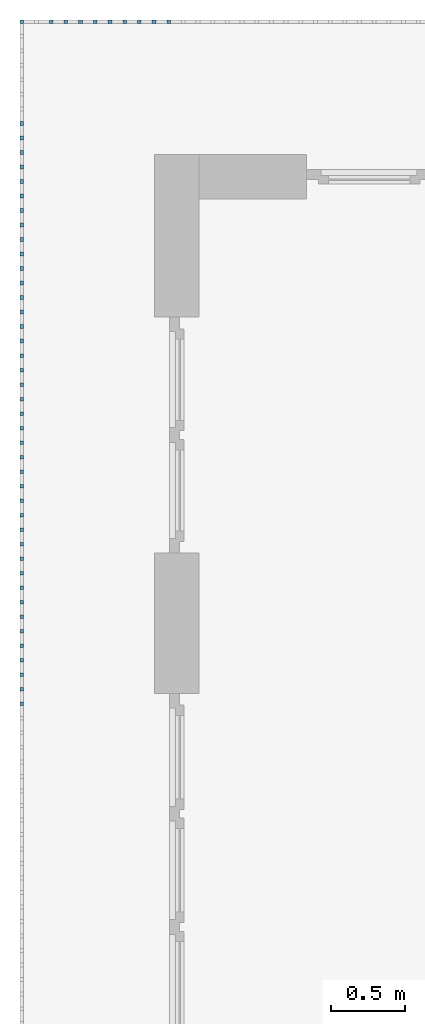
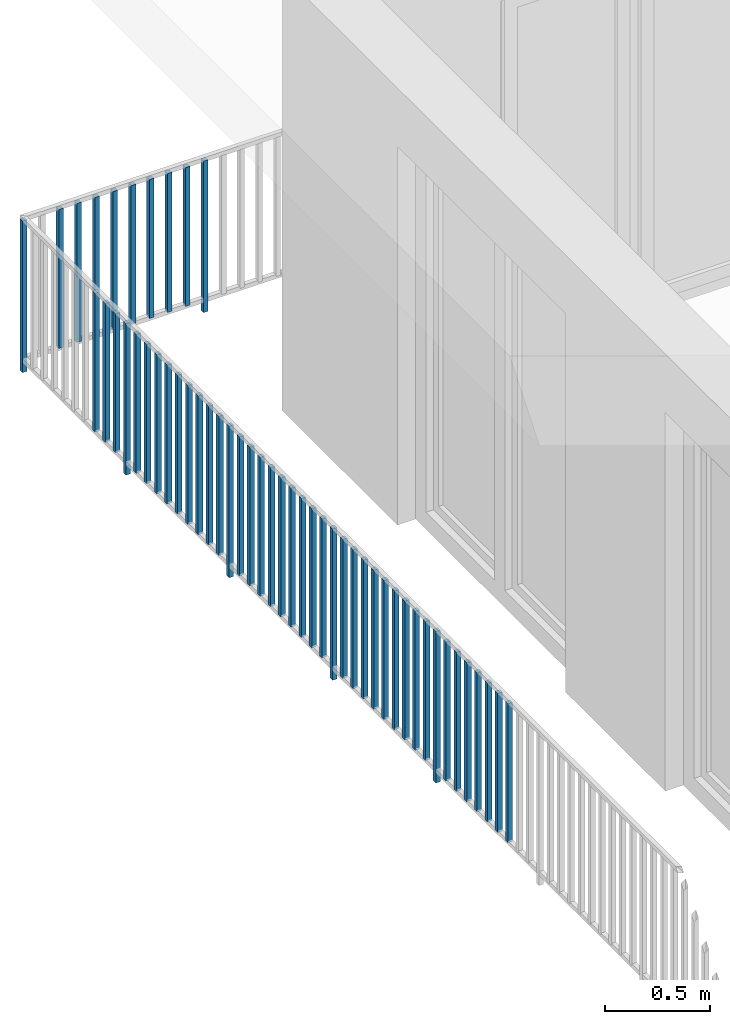
# One storey, part 41 of 48: 51 building element parts, 1 element without a shape of its own.
"""IFC4 building model written with IfcOpenShell, lengths in metres."""

from ifc_helpers import new_model, entity, si_unit, converted_unit, derived_unit, direction, frame, origin_with_axes, place, context, subcontext, project, spatial, polygons, material, type_object, element, aggregate, save


model = new_model("IFC4")

# Units and contexts
model_context = context("Model", 3, precision=1e-05, world=origin_with_axes(), true_north=direction((0.0, 1.0)))
body_context = subcontext(model_context, "Body", "Model", "MODEL_VIEW")
ifc_project = project(units=[si_unit("LENGTHUNIT", "METRE"), si_unit("AREAUNIT", "SQUARE_METRE"), si_unit("VOLUMEUNIT", "CUBIC_METRE"), converted_unit("PLANEANGLEUNIT", "DEGREE", entity("IfcPlaneAngleMeasure", 0.0174532925199), si_unit("PLANEANGLEUNIT", "RADIAN"), dimensions=[0, 0, 0, 0, 0, 0, 0]), converted_unit("TIMEUNIT", "Year", entity("IfcTimeMeasure", 31556926.0), si_unit("TIMEUNIT", "SECOND"), dimensions=[0, 0, 1, 0, 0, 0, 0]), si_unit("MASSUNIT", "GRAM", prefix="KILO"), si_unit("THERMODYNAMICTEMPERATUREUNIT", "DEGREE_CELSIUS"), si_unit("LUMINOUSINTENSITYUNIT", "LUMEN"), si_unit("ENERGYUNIT", "JOULE", prefix="MEGA"), derived_unit("THERMALCONDUCTANCEUNIT", [(si_unit("POWERUNIT", "WATT"), 1), (si_unit("LENGTHUNIT", "METRE"), -1), (si_unit("THERMODYNAMICTEMPERATUREUNIT", "KELVIN"), -1)]), derived_unit("SPECIFICHEATCAPACITYUNIT", [(si_unit("ENERGYUNIT", "JOULE"), 1), (si_unit("MASSUNIT", "GRAM", prefix="KILO"), -1), (si_unit("THERMODYNAMICTEMPERATUREUNIT", "KELVIN"), -1)]), derived_unit("MASSDENSITYUNIT", [(si_unit("MASSUNIT", "GRAM", prefix="KILO"), 1), (si_unit("VOLUMEUNIT", "CUBIC_METRE"), -1)])], contexts=[model_context])

# Site, building, storey
site_placement = place(None, origin_with_axes())
site = spatial("IfcSite", under=ifc_project, at=site_placement, CompositionType="ELEMENT")
building_placement = place(site_placement, origin_with_axes())
building = spatial("IfcBuilding", under=site, at=building_placement, CompositionType="ELEMENT")
storey_placement = place(building_placement, frame((0.0, 0.0, 3.4), z_axis=(0.0, 0.0, 1.0), x_axis=(1.0, 0.0, 0.0)))
storey = spatial("IfcBuildingStorey", under=building, at=storey_placement, Name="1. Geschoss", CompositionType="ELEMENT", Elevation=3.4)

# Railing, building element parts
railing_type = type_object("IfcRailingType", PredefinedType="NOTDEFINED")
railing_placement = place(storey_placement, frame((10.2378006196, 9.82118776896, 0.0), z_axis=(0.0, 0.0, 1.0), x_axis=(1.0, 0.0, 0.0)))
railing = element("IfcRailing", 1, at=railing_placement, inside=storey, type_object=railing_type, PredefinedType="NOTDEFINED")
ifc_material = material()
building_element_part_1_placement = place(railing_placement, origin_with_axes())
building_element_part_1 = element("IfcBuildingElementPart", 2, at=building_element_part_1_placement, material=ifc_material, PredefinedType="NOTDEFINED", context=body_context, shape_type="Tessellation", body=[
    polygons([(-22.8925, 0.0125, 0.0), (-22.8925, -0.0125, 0.0), (-22.8925, -0.0125, 0.88), (-22.8925, 0.0125, 0.88), (-22.8675, 0.0125, 0.0), (-22.8675, -0.0125, 0.0), (-22.8675, -0.0125, 0.88), (-22.8675, 0.0125, 0.88)], [[[1, 2, 3, 4]], [[1, 5, 6, 2]], [[2, 6, 7, 3]], [[4, 3, 7, 8]], [[5, 1, 4, 8]], [[6, 5, 8, 7]]], closed=True),
])
building_element_part_2_placement = place(railing_placement, origin_with_axes())
building_element_part_2 = element("IfcBuildingElementPart", 3, at=building_element_part_2_placement, material=ifc_material, PredefinedType="NOTDEFINED", context=body_context, shape_type="Tessellation", body=[
    polygons([(-21.8977173913, 0.0125, 0.0), (-21.8977173913, -0.0125, 0.0), (-21.8977173913, -0.0125, 0.88), (-21.8977173913, 0.0125, 0.88), (-21.8727173913, 0.0125, 0.0), (-21.8727173913, -0.0125, 0.0), (-21.8727173913, -0.0125, 0.88), (-21.8727173913, 0.0125, 0.88)], [[[1, 2, 3, 4]], [[1, 5, 6, 2]], [[2, 6, 7, 3]], [[4, 3, 7, 8]], [[5, 1, 4, 8]], [[6, 5, 8, 7]]], closed=True),
])
building_element_part_3_placement = place(railing_placement, origin_with_axes())
building_element_part_3 = element("IfcBuildingElementPart", 4, at=building_element_part_3_placement, material=ifc_material, PredefinedType="NOTDEFINED", context=body_context, shape_type="Tessellation", body=[
    polygons([(-21.9971956522, 0.0125, 0.07), (-21.9971956522, -0.0125, 0.07), (-21.9971956522, -0.0125, 0.8775), (-21.9971956522, 0.0125, 0.8775), (-21.9721956522, 0.0125, 0.07), (-21.9721956522, -0.0125, 0.07), (-21.9721956522, -0.0125, 0.8775), (-21.9721956522, 0.0125, 0.8775)], [[[1, 2, 3, 4]], [[1, 5, 6, 2]], [[2, 6, 7, 3]], [[4, 3, 7, 8]], [[5, 1, 4, 8]], [[6, 5, 8, 7]]], closed=True),
])
building_element_part_4_placement = place(railing_placement, origin_with_axes())
building_element_part_4 = element("IfcBuildingElementPart", 5, at=building_element_part_4_placement, material=ifc_material, PredefinedType="NOTDEFINED", context=body_context, shape_type="Tessellation", body=[
    polygons([(-22.096673913, 0.0125, 0.07), (-22.096673913, -0.0125, 0.07), (-22.096673913, -0.0125, 0.8775), (-22.096673913, 0.0125, 0.8775), (-22.071673913, 0.0125, 0.07), (-22.071673913, -0.0125, 0.07), (-22.071673913, -0.0125, 0.8775), (-22.071673913, 0.0125, 0.8775)], [[[1, 2, 3, 4]], [[1, 5, 6, 2]], [[2, 6, 7, 3]], [[4, 3, 7, 8]], [[5, 1, 4, 8]], [[6, 5, 8, 7]]], closed=True),
])
building_element_part_5_placement = place(railing_placement, origin_with_axes())
building_element_part_5 = element("IfcBuildingElementPart", 6, at=building_element_part_5_placement, material=ifc_material, PredefinedType="NOTDEFINED", context=body_context, shape_type="Tessellation", body=[
    polygons([(-22.1961521739, 0.0125, 0.07), (-22.1961521739, -0.0125, 0.07), (-22.1961521739, -0.0125, 0.8775), (-22.1961521739, 0.0125, 0.8775), (-22.1711521739, 0.0125, 0.07), (-22.1711521739, -0.0125, 0.07), (-22.1711521739, -0.0125, 0.8775), (-22.1711521739, 0.0125, 0.8775)], [[[1, 2, 3, 4]], [[1, 5, 6, 2]], [[2, 6, 7, 3]], [[4, 3, 7, 8]], [[5, 1, 4, 8]], [[6, 5, 8, 7]]], closed=True),
])
building_element_part_6_placement = place(railing_placement, origin_with_axes())
building_element_part_6 = element("IfcBuildingElementPart", 7, at=building_element_part_6_placement, material=ifc_material, PredefinedType="NOTDEFINED", context=body_context, shape_type="Tessellation", body=[
    polygons([(-22.2956304348, 0.0125, 0.07), (-22.2956304348, -0.0125, 0.07), (-22.2956304348, -0.0125, 0.8775), (-22.2956304348, 0.0125, 0.8775), (-22.2706304348, 0.0125, 0.07), (-22.2706304348, -0.0125, 0.07), (-22.2706304348, -0.0125, 0.8775), (-22.2706304348, 0.0125, 0.8775)], [[[1, 2, 3, 4]], [[1, 5, 6, 2]], [[2, 6, 7, 3]], [[4, 3, 7, 8]], [[5, 1, 4, 8]], [[6, 5, 8, 7]]], closed=True),
])
building_element_part_7_placement = place(railing_placement, origin_with_axes())
building_element_part_7 = element("IfcBuildingElementPart", 8, at=building_element_part_7_placement, material=ifc_material, PredefinedType="NOTDEFINED", context=body_context, shape_type="Tessellation", body=[
    polygons([(-22.3951086957, 0.0125, 0.07), (-22.3951086957, -0.0125, 0.07), (-22.3951086957, -0.0125, 0.8775), (-22.3951086957, 0.0125, 0.8775), (-22.3701086957, 0.0125, 0.07), (-22.3701086957, -0.0125, 0.07), (-22.3701086957, -0.0125, 0.8775), (-22.3701086957, 0.0125, 0.8775)], [[[1, 2, 3, 4]], [[1, 5, 6, 2]], [[2, 6, 7, 3]], [[4, 3, 7, 8]], [[5, 1, 4, 8]], [[6, 5, 8, 7]]], closed=True),
])
building_element_part_8_placement = place(railing_placement, origin_with_axes())
building_element_part_8 = element("IfcBuildingElementPart", 9, at=building_element_part_8_placement, material=ifc_material, PredefinedType="NOTDEFINED", context=body_context, shape_type="Tessellation", body=[
    polygons([(-22.4945869565, 0.0125, 0.07), (-22.4945869565, -0.0125, 0.07), (-22.4945869565, -0.0125, 0.8775), (-22.4945869565, 0.0125, 0.8775), (-22.4695869565, 0.0125, 0.07), (-22.4695869565, -0.0125, 0.07), (-22.4695869565, -0.0125, 0.8775), (-22.4695869565, 0.0125, 0.8775)], [[[1, 2, 3, 4]], [[1, 5, 6, 2]], [[2, 6, 7, 3]], [[4, 3, 7, 8]], [[5, 1, 4, 8]], [[6, 5, 8, 7]]], closed=True),
])
building_element_part_9_placement = place(railing_placement, origin_with_axes())
building_element_part_9 = element("IfcBuildingElementPart", 10, at=building_element_part_9_placement, material=ifc_material, PredefinedType="NOTDEFINED", context=body_context, shape_type="Tessellation", body=[
    polygons([(-22.5940652174, 0.0125, 0.07), (-22.5940652174, -0.0125, 0.07), (-22.5940652174, -0.0125, 0.8775), (-22.5940652174, 0.0125, 0.8775), (-22.5690652174, 0.0125, 0.07), (-22.5690652174, -0.0125, 0.07), (-22.5690652174, -0.0125, 0.8775), (-22.5690652174, 0.0125, 0.8775)], [[[1, 2, 3, 4]], [[1, 5, 6, 2]], [[2, 6, 7, 3]], [[4, 3, 7, 8]], [[5, 1, 4, 8]], [[6, 5, 8, 7]]], closed=True),
])
building_element_part_10_placement = place(railing_placement, origin_with_axes())
building_element_part_10 = element("IfcBuildingElementPart", 11, at=building_element_part_10_placement, material=ifc_material, PredefinedType="NOTDEFINED", context=body_context, shape_type="Tessellation", body=[
    polygons([(-22.6935434783, 0.0125, 0.07), (-22.6935434783, -0.0125, 0.07), (-22.6935434783, -0.0125, 0.8775), (-22.6935434783, 0.0125, 0.8775), (-22.6685434783, 0.0125, 0.07), (-22.6685434783, -0.0125, 0.07), (-22.6685434783, -0.0125, 0.8775), (-22.6685434783, 0.0125, 0.8775)], [[[1, 2, 3, 4]], [[1, 5, 6, 2]], [[2, 6, 7, 3]], [[4, 3, 7, 8]], [[5, 1, 4, 8]], [[6, 5, 8, 7]]], closed=True),
])
building_element_part_11_placement = place(railing_placement, origin_with_axes())
building_element_part_11 = element("IfcBuildingElementPart", 12, at=building_element_part_11_placement, material=ifc_material, PredefinedType="NOTDEFINED", context=body_context, shape_type="Tessellation", body=[
    polygons([(-22.8925, -0.700833333333, 0.07), (-22.8675, -0.700833333333, 0.07), (-22.8675, -0.700833333333, 0.8775), (-22.8925, -0.700833333333, 0.8775), (-22.8925, -0.675833333333, 0.07), (-22.8675, -0.675833333333, 0.07), (-22.8675, -0.675833333333, 0.8775), (-22.8925, -0.675833333333, 0.8775)], [[[1, 2, 3, 4]], [[1, 5, 6, 2]], [[2, 6, 7, 3]], [[4, 3, 7, 8]], [[5, 1, 4, 8]], [[6, 5, 8, 7]]], closed=True),
])
building_element_part_12_placement = place(railing_placement, origin_with_axes())
building_element_part_12 = element("IfcBuildingElementPart", 13, at=building_element_part_12_placement, material=ifc_material, PredefinedType="NOTDEFINED", context=body_context, shape_type="Tessellation", body=[
    polygons([(-22.8925, -0.799166666667, 0.07), (-22.8675, -0.799166666667, 0.07), (-22.8675, -0.799166666667, 0.8775), (-22.8925, -0.799166666667, 0.8775), (-22.8925, -0.774166666667, 0.07), (-22.8675, -0.774166666667, 0.07), (-22.8675, -0.774166666667, 0.8775), (-22.8925, -0.774166666667, 0.8775)], [[[1, 2, 3, 4]], [[1, 5, 6, 2]], [[2, 6, 7, 3]], [[4, 3, 7, 8]], [[5, 1, 4, 8]], [[6, 5, 8, 7]]], closed=True),
])
building_element_part_13_placement = place(railing_placement, origin_with_axes())
building_element_part_13 = element("IfcBuildingElementPart", 14, at=building_element_part_13_placement, material=ifc_material, PredefinedType="NOTDEFINED", context=body_context, shape_type="Tessellation", body=[
    polygons([(-22.8925, -0.8975, 0.07), (-22.8675, -0.8975, 0.07), (-22.8675, -0.8975, 0.8775), (-22.8925, -0.8975, 0.8775), (-22.8925, -0.8725, 0.07), (-22.8675, -0.8725, 0.07), (-22.8675, -0.8725, 0.8775), (-22.8925, -0.8725, 0.8775)], [[[1, 2, 3, 4]], [[1, 5, 6, 2]], [[2, 6, 7, 3]], [[4, 3, 7, 8]], [[5, 1, 4, 8]], [[6, 5, 8, 7]]], closed=True),
])
building_element_part_14_placement = place(railing_placement, origin_with_axes())
building_element_part_14 = element("IfcBuildingElementPart", 15, at=building_element_part_14_placement, material=ifc_material, PredefinedType="NOTDEFINED", context=body_context, shape_type="Tessellation", body=[
    polygons([(-22.8925, -0.995833333333, 0.0), (-22.8675, -0.995833333333, 0.0), (-22.8675, -0.995833333333, 0.88), (-22.8925, -0.995833333333, 0.88), (-22.8925, -0.970833333333, 0.0), (-22.8675, -0.970833333333, 0.0), (-22.8675, -0.970833333333, 0.88), (-22.8925, -0.970833333333, 0.88)], [[[1, 2, 3, 4]], [[1, 5, 6, 2]], [[2, 6, 7, 3]], [[4, 3, 7, 8]], [[5, 1, 4, 8]], [[6, 5, 8, 7]]], closed=True),
])
building_element_part_15_placement = place(railing_placement, origin_with_axes())
building_element_part_15 = element("IfcBuildingElementPart", 16, at=building_element_part_15_placement, material=ifc_material, PredefinedType="NOTDEFINED", context=body_context, shape_type="Tessellation", body=[
    polygons([(-22.8925, -1.09416666667, 0.07), (-22.8675, -1.09416666667, 0.07), (-22.8675, -1.09416666667, 0.8775), (-22.8925, -1.09416666667, 0.8775), (-22.8925, -1.06916666667, 0.07), (-22.8675, -1.06916666667, 0.07), (-22.8675, -1.06916666667, 0.8775), (-22.8925, -1.06916666667, 0.8775)], [[[1, 2, 3, 4]], [[1, 5, 6, 2]], [[2, 6, 7, 3]], [[4, 3, 7, 8]], [[5, 1, 4, 8]], [[6, 5, 8, 7]]], closed=True),
])
building_element_part_16_placement = place(railing_placement, origin_with_axes())
building_element_part_16 = element("IfcBuildingElementPart", 17, at=building_element_part_16_placement, material=ifc_material, PredefinedType="NOTDEFINED", context=body_context, shape_type="Tessellation", body=[
    polygons([(-22.8925, -1.1925, 0.07), (-22.8675, -1.1925, 0.07), (-22.8675, -1.1925, 0.8775), (-22.8925, -1.1925, 0.8775), (-22.8925, -1.1675, 0.07), (-22.8675, -1.1675, 0.07), (-22.8675, -1.1675, 0.8775), (-22.8925, -1.1675, 0.8775)], [[[1, 2, 3, 4]], [[1, 5, 6, 2]], [[2, 6, 7, 3]], [[4, 3, 7, 8]], [[5, 1, 4, 8]], [[6, 5, 8, 7]]], closed=True),
])
building_element_part_17_placement = place(railing_placement, origin_with_axes())
building_element_part_17 = element("IfcBuildingElementPart", 18, at=building_element_part_17_placement, material=ifc_material, PredefinedType="NOTDEFINED", context=body_context, shape_type="Tessellation", body=[
    polygons([(-22.8925, -1.29083333333, 0.07), (-22.8675, -1.29083333333, 0.07), (-22.8675, -1.29083333333, 0.8775), (-22.8925, -1.29083333333, 0.8775), (-22.8925, -1.26583333333, 0.07), (-22.8675, -1.26583333333, 0.07), (-22.8675, -1.26583333333, 0.8775), (-22.8925, -1.26583333333, 0.8775)], [[[1, 2, 3, 4]], [[1, 5, 6, 2]], [[2, 6, 7, 3]], [[4, 3, 7, 8]], [[5, 1, 4, 8]], [[6, 5, 8, 7]]], closed=True),
])
building_element_part_18_placement = place(railing_placement, origin_with_axes())
building_element_part_18 = element("IfcBuildingElementPart", 19, at=building_element_part_18_placement, material=ifc_material, PredefinedType="NOTDEFINED", context=body_context, shape_type="Tessellation", body=[
    polygons([(-22.8925, -1.38916666667, 0.07), (-22.8675, -1.38916666667, 0.07), (-22.8675, -1.38916666667, 0.8775), (-22.8925, -1.38916666667, 0.8775), (-22.8925, -1.36416666667, 0.07), (-22.8675, -1.36416666667, 0.07), (-22.8675, -1.36416666667, 0.8775), (-22.8925, -1.36416666667, 0.8775)], [[[1, 2, 3, 4]], [[1, 5, 6, 2]], [[2, 6, 7, 3]], [[4, 3, 7, 8]], [[5, 1, 4, 8]], [[6, 5, 8, 7]]], closed=True),
])
building_element_part_19_placement = place(railing_placement, origin_with_axes())
building_element_part_19 = element("IfcBuildingElementPart", 20, at=building_element_part_19_placement, material=ifc_material, PredefinedType="NOTDEFINED", context=body_context, shape_type="Tessellation", body=[
    polygons([(-22.8925, -1.4875, 0.07), (-22.8675, -1.4875, 0.07), (-22.8675, -1.4875, 0.8775), (-22.8925, -1.4875, 0.8775), (-22.8925, -1.4625, 0.07), (-22.8675, -1.4625, 0.07), (-22.8675, -1.4625, 0.8775), (-22.8925, -1.4625, 0.8775)], [[[1, 2, 3, 4]], [[1, 5, 6, 2]], [[2, 6, 7, 3]], [[4, 3, 7, 8]], [[5, 1, 4, 8]], [[6, 5, 8, 7]]], closed=True),
])
building_element_part_20_placement = place(railing_placement, origin_with_axes())
building_element_part_20 = element("IfcBuildingElementPart", 21, at=building_element_part_20_placement, material=ifc_material, PredefinedType="NOTDEFINED", context=body_context, shape_type="Tessellation", body=[
    polygons([(-22.8925, -1.58583333333, 0.07), (-22.8675, -1.58583333333, 0.07), (-22.8675, -1.58583333333, 0.8775), (-22.8925, -1.58583333333, 0.8775), (-22.8925, -1.56083333333, 0.07), (-22.8675, -1.56083333333, 0.07), (-22.8675, -1.56083333333, 0.8775), (-22.8925, -1.56083333333, 0.8775)], [[[1, 2, 3, 4]], [[1, 5, 6, 2]], [[2, 6, 7, 3]], [[4, 3, 7, 8]], [[5, 1, 4, 8]], [[6, 5, 8, 7]]], closed=True),
])
building_element_part_21_placement = place(railing_placement, origin_with_axes())
building_element_part_21 = element("IfcBuildingElementPart", 22, at=building_element_part_21_placement, material=ifc_material, PredefinedType="NOTDEFINED", context=body_context, shape_type="Tessellation", body=[
    polygons([(-22.8925, -1.68416666667, 0.07), (-22.8675, -1.68416666667, 0.07), (-22.8675, -1.68416666667, 0.8775), (-22.8925, -1.68416666667, 0.8775), (-22.8925, -1.65916666667, 0.07), (-22.8675, -1.65916666667, 0.07), (-22.8675, -1.65916666667, 0.8775), (-22.8925, -1.65916666667, 0.8775)], [[[1, 2, 3, 4]], [[1, 5, 6, 2]], [[2, 6, 7, 3]], [[4, 3, 7, 8]], [[5, 1, 4, 8]], [[6, 5, 8, 7]]], closed=True),
])
building_element_part_22_placement = place(railing_placement, origin_with_axes())
building_element_part_22 = element("IfcBuildingElementPart", 23, at=building_element_part_22_placement, material=ifc_material, PredefinedType="NOTDEFINED", context=body_context, shape_type="Tessellation", body=[
    polygons([(-22.8925, -1.7825, 0.07), (-22.8675, -1.7825, 0.07), (-22.8675, -1.7825, 0.8775), (-22.8925, -1.7825, 0.8775), (-22.8925, -1.7575, 0.07), (-22.8675, -1.7575, 0.07), (-22.8675, -1.7575, 0.8775), (-22.8925, -1.7575, 0.8775)], [[[1, 2, 3, 4]], [[1, 5, 6, 2]], [[2, 6, 7, 3]], [[4, 3, 7, 8]], [[5, 1, 4, 8]], [[6, 5, 8, 7]]], closed=True),
])
building_element_part_23_placement = place(railing_placement, origin_with_axes())
building_element_part_23 = element("IfcBuildingElementPart", 24, at=building_element_part_23_placement, material=ifc_material, PredefinedType="NOTDEFINED", context=body_context, shape_type="Tessellation", body=[
    polygons([(-22.8925, -1.88083333333, 0.07), (-22.8675, -1.88083333333, 0.07), (-22.8675, -1.88083333333, 0.8775), (-22.8925, -1.88083333333, 0.8775), (-22.8925, -1.85583333333, 0.07), (-22.8675, -1.85583333333, 0.07), (-22.8675, -1.85583333333, 0.8775), (-22.8925, -1.85583333333, 0.8775)], [[[1, 2, 3, 4]], [[1, 5, 6, 2]], [[2, 6, 7, 3]], [[4, 3, 7, 8]], [[5, 1, 4, 8]], [[6, 5, 8, 7]]], closed=True),
])
building_element_part_24_placement = place(railing_placement, origin_with_axes())
building_element_part_24 = element("IfcBuildingElementPart", 25, at=building_element_part_24_placement, material=ifc_material, PredefinedType="NOTDEFINED", context=body_context, shape_type="Tessellation", body=[
    polygons([(-22.8925, -1.97916666667, 0.0), (-22.8675, -1.97916666667, 0.0), (-22.8675, -1.97916666667, 0.88), (-22.8925, -1.97916666667, 0.88), (-22.8925, -1.95416666667, 0.0), (-22.8675, -1.95416666667, 0.0), (-22.8675, -1.95416666667, 0.88), (-22.8925, -1.95416666667, 0.88)], [[[1, 2, 3, 4]], [[1, 5, 6, 2]], [[2, 6, 7, 3]], [[4, 3, 7, 8]], [[5, 1, 4, 8]], [[6, 5, 8, 7]]], closed=True),
])
building_element_part_25_placement = place(railing_placement, origin_with_axes())
building_element_part_25 = element("IfcBuildingElementPart", 26, at=building_element_part_25_placement, material=ifc_material, PredefinedType="NOTDEFINED", context=body_context, shape_type="Tessellation", body=[
    polygons([(-22.8925, -2.0775, 0.07), (-22.8675, -2.0775, 0.07), (-22.8675, -2.0775, 0.8775), (-22.8925, -2.0775, 0.8775), (-22.8925, -2.0525, 0.07), (-22.8675, -2.0525, 0.07), (-22.8675, -2.0525, 0.8775), (-22.8925, -2.0525, 0.8775)], [[[1, 2, 3, 4]], [[1, 5, 6, 2]], [[2, 6, 7, 3]], [[4, 3, 7, 8]], [[5, 1, 4, 8]], [[6, 5, 8, 7]]], closed=True),
])
building_element_part_26_placement = place(railing_placement, origin_with_axes())
building_element_part_26 = element("IfcBuildingElementPart", 27, at=building_element_part_26_placement, material=ifc_material, PredefinedType="NOTDEFINED", context=body_context, shape_type="Tessellation", body=[
    polygons([(-22.8925, -2.17583333333, 0.07), (-22.8675, -2.17583333333, 0.07), (-22.8675, -2.17583333333, 0.8775), (-22.8925, -2.17583333333, 0.8775), (-22.8925, -2.15083333333, 0.07), (-22.8675, -2.15083333333, 0.07), (-22.8675, -2.15083333333, 0.8775), (-22.8925, -2.15083333333, 0.8775)], [[[1, 2, 3, 4]], [[1, 5, 6, 2]], [[2, 6, 7, 3]], [[4, 3, 7, 8]], [[5, 1, 4, 8]], [[6, 5, 8, 7]]], closed=True),
])
building_element_part_27_placement = place(railing_placement, origin_with_axes())
building_element_part_27 = element("IfcBuildingElementPart", 28, at=building_element_part_27_placement, material=ifc_material, PredefinedType="NOTDEFINED", context=body_context, shape_type="Tessellation", body=[
    polygons([(-22.8925, -2.27416666667, 0.07), (-22.8675, -2.27416666667, 0.07), (-22.8675, -2.27416666667, 0.8775), (-22.8925, -2.27416666667, 0.8775), (-22.8925, -2.24916666667, 0.07), (-22.8675, -2.24916666667, 0.07), (-22.8675, -2.24916666667, 0.8775), (-22.8925, -2.24916666667, 0.8775)], [[[1, 2, 3, 4]], [[1, 5, 6, 2]], [[2, 6, 7, 3]], [[4, 3, 7, 8]], [[5, 1, 4, 8]], [[6, 5, 8, 7]]], closed=True),
])
building_element_part_28_placement = place(railing_placement, origin_with_axes())
building_element_part_28 = element("IfcBuildingElementPart", 29, at=building_element_part_28_placement, material=ifc_material, PredefinedType="NOTDEFINED", context=body_context, shape_type="Tessellation", body=[
    polygons([(-22.8925, -2.3725, 0.07), (-22.8675, -2.3725, 0.07), (-22.8675, -2.3725, 0.8775), (-22.8925, -2.3725, 0.8775), (-22.8925, -2.3475, 0.07), (-22.8675, -2.3475, 0.07), (-22.8675, -2.3475, 0.8775), (-22.8925, -2.3475, 0.8775)], [[[1, 2, 3, 4]], [[1, 5, 6, 2]], [[2, 6, 7, 3]], [[4, 3, 7, 8]], [[5, 1, 4, 8]], [[6, 5, 8, 7]]], closed=True),
])
building_element_part_29_placement = place(railing_placement, origin_with_axes())
building_element_part_29 = element("IfcBuildingElementPart", 30, at=building_element_part_29_placement, material=ifc_material, PredefinedType="NOTDEFINED", context=body_context, shape_type="Tessellation", body=[
    polygons([(-22.8925, -2.47083333333, 0.07), (-22.8675, -2.47083333333, 0.07), (-22.8675, -2.47083333333, 0.8775), (-22.8925, -2.47083333333, 0.8775), (-22.8925, -2.44583333333, 0.07), (-22.8675, -2.44583333333, 0.07), (-22.8675, -2.44583333333, 0.8775), (-22.8925, -2.44583333333, 0.8775)], [[[1, 2, 3, 4]], [[1, 5, 6, 2]], [[2, 6, 7, 3]], [[4, 3, 7, 8]], [[5, 1, 4, 8]], [[6, 5, 8, 7]]], closed=True),
])
building_element_part_30_placement = place(railing_placement, origin_with_axes())
building_element_part_30 = element("IfcBuildingElementPart", 31, at=building_element_part_30_placement, material=ifc_material, PredefinedType="NOTDEFINED", context=body_context, shape_type="Tessellation", body=[
    polygons([(-22.8925, -2.56916666667, 0.07), (-22.8675, -2.56916666667, 0.07), (-22.8675, -2.56916666667, 0.8775), (-22.8925, -2.56916666667, 0.8775), (-22.8925, -2.54416666667, 0.07), (-22.8675, -2.54416666667, 0.07), (-22.8675, -2.54416666667, 0.8775), (-22.8925, -2.54416666667, 0.8775)], [[[1, 2, 3, 4]], [[1, 5, 6, 2]], [[2, 6, 7, 3]], [[4, 3, 7, 8]], [[5, 1, 4, 8]], [[6, 5, 8, 7]]], closed=True),
])
building_element_part_31_placement = place(railing_placement, origin_with_axes())
building_element_part_31 = element("IfcBuildingElementPart", 32, at=building_element_part_31_placement, material=ifc_material, PredefinedType="NOTDEFINED", context=body_context, shape_type="Tessellation", body=[
    polygons([(-22.8925, -2.6675, 0.07), (-22.8675, -2.6675, 0.07), (-22.8675, -2.6675, 0.8775), (-22.8925, -2.6675, 0.8775), (-22.8925, -2.6425, 0.07), (-22.8675, -2.6425, 0.07), (-22.8675, -2.6425, 0.8775), (-22.8925, -2.6425, 0.8775)], [[[1, 2, 3, 4]], [[1, 5, 6, 2]], [[2, 6, 7, 3]], [[4, 3, 7, 8]], [[5, 1, 4, 8]], [[6, 5, 8, 7]]], closed=True),
])
building_element_part_32_placement = place(railing_placement, origin_with_axes())
building_element_part_32 = element("IfcBuildingElementPart", 33, at=building_element_part_32_placement, material=ifc_material, PredefinedType="NOTDEFINED", context=body_context, shape_type="Tessellation", body=[
    polygons([(-22.8925, -2.76583333333, 0.07), (-22.8675, -2.76583333333, 0.07), (-22.8675, -2.76583333333, 0.8775), (-22.8925, -2.76583333333, 0.8775), (-22.8925, -2.74083333333, 0.07), (-22.8675, -2.74083333333, 0.07), (-22.8675, -2.74083333333, 0.8775), (-22.8925, -2.74083333333, 0.8775)], [[[1, 2, 3, 4]], [[1, 5, 6, 2]], [[2, 6, 7, 3]], [[4, 3, 7, 8]], [[5, 1, 4, 8]], [[6, 5, 8, 7]]], closed=True),
])
building_element_part_33_placement = place(railing_placement, origin_with_axes())
building_element_part_33 = element("IfcBuildingElementPart", 34, at=building_element_part_33_placement, material=ifc_material, PredefinedType="NOTDEFINED", context=body_context, shape_type="Tessellation", body=[
    polygons([(-22.8925, -2.86416666667, 0.07), (-22.8675, -2.86416666667, 0.07), (-22.8675, -2.86416666667, 0.8775), (-22.8925, -2.86416666667, 0.8775), (-22.8925, -2.83916666667, 0.07), (-22.8675, -2.83916666667, 0.07), (-22.8675, -2.83916666667, 0.8775), (-22.8925, -2.83916666667, 0.8775)], [[[1, 2, 3, 4]], [[1, 5, 6, 2]], [[2, 6, 7, 3]], [[4, 3, 7, 8]], [[5, 1, 4, 8]], [[6, 5, 8, 7]]], closed=True),
])
building_element_part_34_placement = place(railing_placement, origin_with_axes())
building_element_part_34 = element("IfcBuildingElementPart", 35, at=building_element_part_34_placement, material=ifc_material, PredefinedType="NOTDEFINED", context=body_context, shape_type="Tessellation", body=[
    polygons([(-22.8925, -2.9625, 0.0), (-22.8675, -2.9625, 0.0), (-22.8675, -2.9625, 0.88), (-22.8925, -2.9625, 0.88), (-22.8925, -2.9375, 0.0), (-22.8675, -2.9375, 0.0), (-22.8675, -2.9375, 0.88), (-22.8925, -2.9375, 0.88)], [[[1, 2, 3, 4]], [[1, 5, 6, 2]], [[2, 6, 7, 3]], [[4, 3, 7, 8]], [[5, 1, 4, 8]], [[6, 5, 8, 7]]], closed=True),
])
building_element_part_35_placement = place(railing_placement, origin_with_axes())
building_element_part_35 = element("IfcBuildingElementPart", 36, at=building_element_part_35_placement, material=ifc_material, PredefinedType="NOTDEFINED", context=body_context, shape_type="Tessellation", body=[
    polygons([(-22.8925, -3.06083333333, 0.07), (-22.8675, -3.06083333333, 0.07), (-22.8675, -3.06083333333, 0.8775), (-22.8925, -3.06083333333, 0.8775), (-22.8925, -3.03583333333, 0.07), (-22.8675, -3.03583333333, 0.07), (-22.8675, -3.03583333333, 0.8775), (-22.8925, -3.03583333333, 0.8775)], [[[1, 2, 3, 4]], [[1, 5, 6, 2]], [[2, 6, 7, 3]], [[4, 3, 7, 8]], [[5, 1, 4, 8]], [[6, 5, 8, 7]]], closed=True),
])
building_element_part_36_placement = place(railing_placement, origin_with_axes())
building_element_part_36 = element("IfcBuildingElementPart", 37, at=building_element_part_36_placement, material=ifc_material, PredefinedType="NOTDEFINED", context=body_context, shape_type="Tessellation", body=[
    polygons([(-22.8925, -3.15916666667, 0.07), (-22.8675, -3.15916666667, 0.07), (-22.8675, -3.15916666667, 0.8775), (-22.8925, -3.15916666667, 0.8775), (-22.8925, -3.13416666667, 0.07), (-22.8675, -3.13416666667, 0.07), (-22.8675, -3.13416666667, 0.8775), (-22.8925, -3.13416666667, 0.8775)], [[[1, 2, 3, 4]], [[1, 5, 6, 2]], [[2, 6, 7, 3]], [[4, 3, 7, 8]], [[5, 1, 4, 8]], [[6, 5, 8, 7]]], closed=True),
])
building_element_part_37_placement = place(railing_placement, origin_with_axes())
building_element_part_37 = element("IfcBuildingElementPart", 38, at=building_element_part_37_placement, material=ifc_material, PredefinedType="NOTDEFINED", context=body_context, shape_type="Tessellation", body=[
    polygons([(-22.8925, -3.2575, 0.07), (-22.8675, -3.2575, 0.07), (-22.8675, -3.2575, 0.8775), (-22.8925, -3.2575, 0.8775), (-22.8925, -3.2325, 0.07), (-22.8675, -3.2325, 0.07), (-22.8675, -3.2325, 0.8775), (-22.8925, -3.2325, 0.8775)], [[[1, 2, 3, 4]], [[1, 5, 6, 2]], [[2, 6, 7, 3]], [[4, 3, 7, 8]], [[5, 1, 4, 8]], [[6, 5, 8, 7]]], closed=True),
])
building_element_part_38_placement = place(railing_placement, origin_with_axes())
building_element_part_38 = element("IfcBuildingElementPart", 39, at=building_element_part_38_placement, material=ifc_material, PredefinedType="NOTDEFINED", context=body_context, shape_type="Tessellation", body=[
    polygons([(-22.8925, -3.35583333333, 0.07), (-22.8675, -3.35583333333, 0.07), (-22.8675, -3.35583333333, 0.8775), (-22.8925, -3.35583333333, 0.8775), (-22.8925, -3.33083333333, 0.07), (-22.8675, -3.33083333333, 0.07), (-22.8675, -3.33083333333, 0.8775), (-22.8925, -3.33083333333, 0.8775)], [[[1, 2, 3, 4]], [[1, 5, 6, 2]], [[2, 6, 7, 3]], [[4, 3, 7, 8]], [[5, 1, 4, 8]], [[6, 5, 8, 7]]], closed=True),
])
building_element_part_39_placement = place(railing_placement, origin_with_axes())
building_element_part_39 = element("IfcBuildingElementPart", 40, at=building_element_part_39_placement, material=ifc_material, PredefinedType="NOTDEFINED", context=body_context, shape_type="Tessellation", body=[
    polygons([(-22.8925, -3.45416666667, 0.07), (-22.8675, -3.45416666667, 0.07), (-22.8675, -3.45416666667, 0.8775), (-22.8925, -3.45416666667, 0.8775), (-22.8925, -3.42916666667, 0.07), (-22.8675, -3.42916666667, 0.07), (-22.8675, -3.42916666667, 0.8775), (-22.8925, -3.42916666667, 0.8775)], [[[1, 2, 3, 4]], [[1, 5, 6, 2]], [[2, 6, 7, 3]], [[4, 3, 7, 8]], [[5, 1, 4, 8]], [[6, 5, 8, 7]]], closed=True),
])
building_element_part_40_placement = place(railing_placement, origin_with_axes())
building_element_part_40 = element("IfcBuildingElementPart", 41, at=building_element_part_40_placement, material=ifc_material, PredefinedType="NOTDEFINED", context=body_context, shape_type="Tessellation", body=[
    polygons([(-22.8925, -3.5525, 0.07), (-22.8675, -3.5525, 0.07), (-22.8675, -3.5525, 0.8775), (-22.8925, -3.5525, 0.8775), (-22.8925, -3.5275, 0.07), (-22.8675, -3.5275, 0.07), (-22.8675, -3.5275, 0.8775), (-22.8925, -3.5275, 0.8775)], [[[1, 2, 3, 4]], [[1, 5, 6, 2]], [[2, 6, 7, 3]], [[4, 3, 7, 8]], [[5, 1, 4, 8]], [[6, 5, 8, 7]]], closed=True),
])
building_element_part_41_placement = place(railing_placement, origin_with_axes())
building_element_part_41 = element("IfcBuildingElementPart", 42, at=building_element_part_41_placement, material=ifc_material, PredefinedType="NOTDEFINED", context=body_context, shape_type="Tessellation", body=[
    polygons([(-22.8925, -3.65083333333, 0.07), (-22.8675, -3.65083333333, 0.07), (-22.8675, -3.65083333333, 0.8775), (-22.8925, -3.65083333333, 0.8775), (-22.8925, -3.62583333333, 0.07), (-22.8675, -3.62583333333, 0.07), (-22.8675, -3.62583333333, 0.8775), (-22.8925, -3.62583333333, 0.8775)], [[[1, 2, 3, 4]], [[1, 5, 6, 2]], [[2, 6, 7, 3]], [[4, 3, 7, 8]], [[5, 1, 4, 8]], [[6, 5, 8, 7]]], closed=True),
])
building_element_part_42_placement = place(railing_placement, origin_with_axes())
building_element_part_42 = element("IfcBuildingElementPart", 43, at=building_element_part_42_placement, material=ifc_material, PredefinedType="NOTDEFINED", context=body_context, shape_type="Tessellation", body=[
    polygons([(-22.8925, -3.74916666667, 0.07), (-22.8675, -3.74916666667, 0.07), (-22.8675, -3.74916666667, 0.8775), (-22.8925, -3.74916666667, 0.8775), (-22.8925, -3.72416666667, 0.07), (-22.8675, -3.72416666667, 0.07), (-22.8675, -3.72416666667, 0.8775), (-22.8925, -3.72416666667, 0.8775)], [[[1, 2, 3, 4]], [[1, 5, 6, 2]], [[2, 6, 7, 3]], [[4, 3, 7, 8]], [[5, 1, 4, 8]], [[6, 5, 8, 7]]], closed=True),
])
building_element_part_43_placement = place(railing_placement, origin_with_axes())
building_element_part_43 = element("IfcBuildingElementPart", 44, at=building_element_part_43_placement, material=ifc_material, PredefinedType="NOTDEFINED", context=body_context, shape_type="Tessellation", body=[
    polygons([(-22.8925, -3.8475, 0.07), (-22.8675, -3.8475, 0.07), (-22.8675, -3.8475, 0.8775), (-22.8925, -3.8475, 0.8775), (-22.8925, -3.8225, 0.07), (-22.8675, -3.8225, 0.07), (-22.8675, -3.8225, 0.8775), (-22.8925, -3.8225, 0.8775)], [[[1, 2, 3, 4]], [[1, 5, 6, 2]], [[2, 6, 7, 3]], [[4, 3, 7, 8]], [[5, 1, 4, 8]], [[6, 5, 8, 7]]], closed=True),
])
building_element_part_44_placement = place(railing_placement, origin_with_axes())
building_element_part_44 = element("IfcBuildingElementPart", 45, at=building_element_part_44_placement, material=ifc_material, PredefinedType="NOTDEFINED", context=body_context, shape_type="Tessellation", body=[
    polygons([(-22.8925, -3.94583333333, 0.0), (-22.8675, -3.94583333333, 0.0), (-22.8675, -3.94583333333, 0.88), (-22.8925, -3.94583333333, 0.88), (-22.8925, -3.92083333333, 0.0), (-22.8675, -3.92083333333, 0.0), (-22.8675, -3.92083333333, 0.88), (-22.8925, -3.92083333333, 0.88)], [[[1, 2, 3, 4]], [[1, 5, 6, 2]], [[2, 6, 7, 3]], [[4, 3, 7, 8]], [[5, 1, 4, 8]], [[6, 5, 8, 7]]], closed=True),
])
building_element_part_45_placement = place(railing_placement, origin_with_axes())
building_element_part_45 = element("IfcBuildingElementPart", 46, at=building_element_part_45_placement, material=ifc_material, PredefinedType="NOTDEFINED", context=body_context, shape_type="Tessellation", body=[
    polygons([(-22.8925, -4.04416666667, 0.07), (-22.8675, -4.04416666667, 0.07), (-22.8675, -4.04416666667, 0.8775), (-22.8925, -4.04416666667, 0.8775), (-22.8925, -4.01916666667, 0.07), (-22.8675, -4.01916666667, 0.07), (-22.8675, -4.01916666667, 0.8775), (-22.8925, -4.01916666667, 0.8775)], [[[1, 2, 3, 4]], [[1, 5, 6, 2]], [[2, 6, 7, 3]], [[4, 3, 7, 8]], [[5, 1, 4, 8]], [[6, 5, 8, 7]]], closed=True),
])
building_element_part_46_placement = place(railing_placement, origin_with_axes())
building_element_part_46 = element("IfcBuildingElementPart", 47, at=building_element_part_46_placement, material=ifc_material, PredefinedType="NOTDEFINED", context=body_context, shape_type="Tessellation", body=[
    polygons([(-22.8925, -4.1425, 0.07), (-22.8675, -4.1425, 0.07), (-22.8675, -4.1425, 0.8775), (-22.8925, -4.1425, 0.8775), (-22.8925, -4.1175, 0.07), (-22.8675, -4.1175, 0.07), (-22.8675, -4.1175, 0.8775), (-22.8925, -4.1175, 0.8775)], [[[1, 2, 3, 4]], [[1, 5, 6, 2]], [[2, 6, 7, 3]], [[4, 3, 7, 8]], [[5, 1, 4, 8]], [[6, 5, 8, 7]]], closed=True),
])
building_element_part_47_placement = place(railing_placement, origin_with_axes())
building_element_part_47 = element("IfcBuildingElementPart", 48, at=building_element_part_47_placement, material=ifc_material, PredefinedType="NOTDEFINED", context=body_context, shape_type="Tessellation", body=[
    polygons([(-22.8925, -4.24083333333, 0.07), (-22.8675, -4.24083333333, 0.07), (-22.8675, -4.24083333333, 0.8775), (-22.8925, -4.24083333333, 0.8775), (-22.8925, -4.21583333333, 0.07), (-22.8675, -4.21583333333, 0.07), (-22.8675, -4.21583333333, 0.8775), (-22.8925, -4.21583333333, 0.8775)], [[[1, 2, 3, 4]], [[1, 5, 6, 2]], [[2, 6, 7, 3]], [[4, 3, 7, 8]], [[5, 1, 4, 8]], [[6, 5, 8, 7]]], closed=True),
])
building_element_part_48_placement = place(railing_placement, origin_with_axes())
building_element_part_48 = element("IfcBuildingElementPart", 49, at=building_element_part_48_placement, material=ifc_material, PredefinedType="NOTDEFINED", context=body_context, shape_type="Tessellation", body=[
    polygons([(-22.8925, -4.33916666667, 0.07), (-22.8675, -4.33916666667, 0.07), (-22.8675, -4.33916666667, 0.8775), (-22.8925, -4.33916666667, 0.8775), (-22.8925, -4.31416666667, 0.07), (-22.8675, -4.31416666667, 0.07), (-22.8675, -4.31416666667, 0.8775), (-22.8925, -4.31416666667, 0.8775)], [[[1, 2, 3, 4]], [[1, 5, 6, 2]], [[2, 6, 7, 3]], [[4, 3, 7, 8]], [[5, 1, 4, 8]], [[6, 5, 8, 7]]], closed=True),
])
building_element_part_49_placement = place(railing_placement, origin_with_axes())
building_element_part_49 = element("IfcBuildingElementPart", 50, at=building_element_part_49_placement, material=ifc_material, PredefinedType="NOTDEFINED", context=body_context, shape_type="Tessellation", body=[
    polygons([(-22.8925, -4.4375, 0.07), (-22.8675, -4.4375, 0.07), (-22.8675, -4.4375, 0.8775), (-22.8925, -4.4375, 0.8775), (-22.8925, -4.4125, 0.07), (-22.8675, -4.4125, 0.07), (-22.8675, -4.4125, 0.8775), (-22.8925, -4.4125, 0.8775)], [[[1, 2, 3, 4]], [[1, 5, 6, 2]], [[2, 6, 7, 3]], [[4, 3, 7, 8]], [[5, 1, 4, 8]], [[6, 5, 8, 7]]], closed=True),
])
building_element_part_50_placement = place(railing_placement, origin_with_axes())
building_element_part_50 = element("IfcBuildingElementPart", 51, at=building_element_part_50_placement, material=ifc_material, PredefinedType="NOTDEFINED", context=body_context, shape_type="Tessellation", body=[
    polygons([(-22.8925, -4.53583333333, 0.07), (-22.8675, -4.53583333333, 0.07), (-22.8675, -4.53583333333, 0.8775), (-22.8925, -4.53583333333, 0.8775), (-22.8925, -4.51083333333, 0.07), (-22.8675, -4.51083333333, 0.07), (-22.8675, -4.51083333333, 0.8775), (-22.8925, -4.51083333333, 0.8775)], [[[1, 2, 3, 4]], [[1, 5, 6, 2]], [[2, 6, 7, 3]], [[4, 3, 7, 8]], [[5, 1, 4, 8]], [[6, 5, 8, 7]]], closed=True),
])
building_element_part_51_placement = place(railing_placement, origin_with_axes())
building_element_part_51 = element("IfcBuildingElementPart", 52, at=building_element_part_51_placement, material=ifc_material, PredefinedType="NOTDEFINED", context=body_context, shape_type="Tessellation", body=[
    polygons([(-22.8925, -4.63416666667, 0.07), (-22.8675, -4.63416666667, 0.07), (-22.8675, -4.63416666667, 0.8775), (-22.8925, -4.63416666667, 0.8775), (-22.8925, -4.60916666667, 0.07), (-22.8675, -4.60916666667, 0.07), (-22.8675, -4.60916666667, 0.8775), (-22.8925, -4.60916666667, 0.8775)], [[[1, 2, 3, 4]], [[1, 5, 6, 2]], [[2, 6, 7, 3]], [[4, 3, 7, 8]], [[5, 1, 4, 8]], [[6, 5, 8, 7]]], closed=True),
])
aggregate(railing, [building_element_part_1, building_element_part_2, building_element_part_3, building_element_part_4, building_element_part_5, building_element_part_6, building_element_part_7, building_element_part_8, building_element_part_9, building_element_part_10, building_element_part_11, building_element_part_12, building_element_part_13, building_element_part_14, building_element_part_15, building_element_part_16, building_element_part_17, building_element_part_18, building_element_part_19, building_element_part_20, building_element_part_21, building_element_part_22, building_element_part_23, building_element_part_24, building_element_part_25, building_element_part_26, building_element_part_27, building_element_part_28, building_element_part_29, building_element_part_30, building_element_part_31, building_element_part_32, building_element_part_33, building_element_part_34, building_element_part_35, building_element_part_36, building_element_part_37, building_element_part_38, building_element_part_39, building_element_part_40, building_element_part_41, building_element_part_42, building_element_part_43, building_element_part_44, building_element_part_45, building_element_part_46, building_element_part_47, building_element_part_48, building_element_part_49, building_element_part_50, building_element_part_51])

save(model, "model.ifc")
